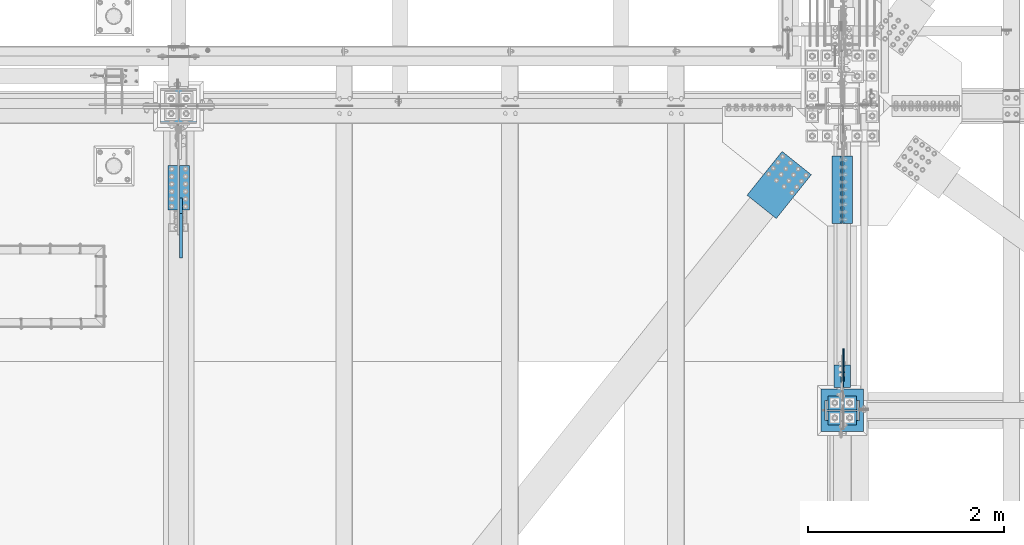
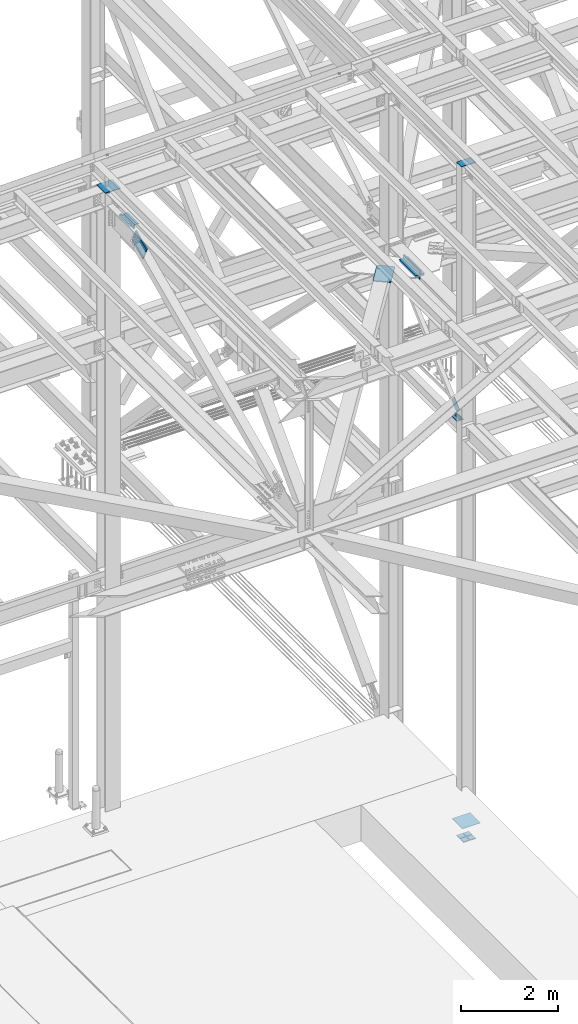
# One storey, part 2543 of 3843: 16 beams, 2 members, 11 elements without a shape of their own.
"""IFC2X3 building model written with IfcOpenShell, lengths in millimetres."""

import ifcopenshell
import ifcopenshell.guid

model = None  # the IFC model being written
_history = None  # IfcOwnerHistory: only IFC2X3 demands one
_inside = {}  # id of a spatial element -> (the spatial element, [elements in it])
_under = {}  # id of a project, library or spatial element -> (it, [spatial elements below it])
_declared = {}  # id of a project -> (the project, [libraries it declares])
_typed = {}  # id of a type object -> (the type object, [elements of that type])
_made_of = {}  # id of a material, layer set ... -> (it, [elements and type objects made of it])


def new_model(schema):
    """Start an empty IFC model of exactly this schema.

    Asked for "IFC4X3", IfcOpenShell would pick the latest addendum, in which some entities
    have other attributes; the version numbers below select the first issue.
    IFC2X3 requires an IfcOwnerHistory on every rooted entity: one is made here for all.
    """
    global model, _history
    if schema == "IFC4X3":
        model = ifcopenshell.file(schema_version=(4, 3, 0, 0))
    else:
        model = ifcopenshell.file(schema=schema)
    _inside.clear()
    _under.clear()
    _declared.clear()
    _typed.clear()
    _made_of.clear()
    _history = None
    if model.schema == "IFC2X3":
        org = make("IfcOrganization", Name="unknown")
        user = make(
            "IfcPersonAndOrganization",
            ThePerson=make("IfcPerson", FamilyName="unknown"),
            TheOrganization=org,
        )
        app = make(
            "IfcApplication",
            ApplicationDeveloper=org,
            Version="unknown",
            ApplicationFullName="unknown",
            ApplicationIdentifier="unknown",
        )
        _history = make(
            "IfcOwnerHistory",
            OwningUser=user,
            OwningApplication=app,
            ChangeAction="ADDED",
            CreationDate=0,
        )
    return model


def make(cls, **values):
    """One entity of the class cls with the attributes given. An attribute that is None is left unset."""
    return model.create_entity(
        cls, **{name: value for name, value in values.items() if value is not None}
    )


def rooted(cls, **values):
    """An entity with a GlobalId (a new one), such as an element, a storey or a relation."""
    return make(cls, GlobalId=ifcopenshell.guid.new(), OwnerHistory=_history, **values)


def si_unit(unit_type, name, prefix=None):
    """IfcSIUnit, for example si_unit("LENGTHUNIT", "METRE", prefix="MILLI")."""
    return make("IfcSIUnit", UnitType=unit_type, Prefix=prefix, Name=name)


def assignment(units):
    """IfcUnitAssignment: the units of a project."""
    return None if units is None else make("IfcUnitAssignment", Units=units)


def point(xyz):
    """IfcCartesianPoint."""
    return None if xyz is None else make("IfcCartesianPoint", Coordinates=xyz)


def direction(xyz):
    """IfcDirection."""
    return None if xyz is None else make("IfcDirection", DirectionRatios=xyz)


def frame(location, z_axis=None, x_axis=None):
    """IfcAxis2Placement3D, a coordinate frame: its origin and axes. An axis left out is left unset."""
    return make(
        "IfcAxis2Placement3D",
        Location=point(location),
        Axis=direction(z_axis),
        RefDirection=direction(x_axis),
    )


def origin_with_axes():
    """The frame at (0, 0, 0) with the z axis (0, 0, 1) and the x axis (1, 0, 0) written out."""
    return frame((0.0, 0.0, 0.0), z_axis=(0.0, 0.0, 1.0), x_axis=(1.0, 0.0, 0.0))


def place(relative_to, where):
    """IfcLocalPlacement: puts the frame where relative to a parent placement (None: the world)."""
    return make(
        "IfcLocalPlacement", PlacementRelTo=relative_to, RelativePlacement=where
    )


def context(
    kind, dimensions, precision=None, world=None, true_north=None, identifier=None
):
    """IfcGeometricRepresentationContext, for example the 3D "Model" context."""
    return make(
        "IfcGeometricRepresentationContext",
        ContextIdentifier=identifier,
        ContextType=kind,
        CoordinateSpaceDimension=dimensions,
        Precision=precision,
        WorldCoordinateSystem=world,
        TrueNorth=true_north,
    )


def subcontext(parent, identifier, kind, view, scale=None):
    """IfcGeometricRepresentationSubContext, for example "Body" below "Model"."""
    return make(
        "IfcGeometricRepresentationSubContext",
        ContextIdentifier=identifier,
        ContextType=kind,
        ParentContext=parent,
        TargetScale=scale,
        TargetView=view,
    )


def project(units=None, contexts=None):
    """IfcProject with its units and contexts."""
    return rooted(
        "IfcProject",
        Name="project",
        RepresentationContexts=contexts,
        UnitsInContext=assignment(units),
    )


def spatial(cls, under=None, at=None, **own):
    """A site, building, storey or space (cls), placed at a placement, below another one or the project."""
    s = rooted(cls, ObjectPlacement=at, **own)
    if under is not None:
        _under.setdefault(under.id(), (under, []))[1].append(s)
    return s


def faces_of(points, faces, orient=None, outer=None):
    """IfcFace entities. A face is a list of loops; a loop is a list of indices into points, from 0.

    orient and outer hold one flag for each loop. By default every Orientation is true, the
    first loop of a face is its IfcFaceOuterBound and the others are IfcFaceBound.
    """
    made = []
    for i, loops in enumerate(faces):
        bounds = []
        for j, loop in enumerate(loops):
            is_outer = j == 0 if outer is None else outer[i][j]
            bounds.append(
                make(
                    "IfcFaceOuterBound" if is_outer else "IfcFaceBound",
                    Bound=make("IfcPolyLoop", Polygon=[points[k] for k in loop]),
                    Orientation=True if orient is None else orient[i][j],
                )
            )
        made.append(make("IfcFace", Bounds=bounds))
    return made


def faceted_brep(points, faces, orient=None, outer=None, voids=None):
    """IfcFacetedBrep: a solid bounded by flat faces; with voids (closed shells), ...WithVoids."""
    shared = [point(p) for p in points]
    hull = make("IfcClosedShell", CfsFaces=faces_of(shared, faces, orient, outer))
    if voids is None:
        return make("IfcFacetedBrep", Outer=hull)
    return make(
        "IfcFacetedBrepWithVoids",
        Outer=hull,
        Voids=[
            make(cls, CfsFaces=faces_of(shared, fs, o, b)) for cls, fs, o, b in voids
        ],
    )


def shape(context_of_items, identifier, shape_type, items):
    """IfcShapeRepresentation: the items that make up one representation, for example the "Body"."""
    return make(
        "IfcShapeRepresentation",
        ContextOfItems=context_of_items,
        RepresentationIdentifier=identifier,
        RepresentationType=shape_type,
        Items=items,
    )


def material(Name=None, Category=None):
    """IfcMaterial."""
    return make("IfcMaterial", Name=Name, Category=Category)


def made_of(thing, what):
    """Note that an element or type object is made of a material, layer set ...; save() writes the relation."""
    if what is not None:
        _made_of.setdefault(what.id(), (what, []))[1].append(thing)
    return thing


def type_object(cls, material=None, **own):
    """A type object (cls), such as IfcWallType, which elements share."""
    return made_of(rooted(cls, **own), material)


def element(
    cls,
    number,
    at=None,
    inside=None,
    cuts=None,
    type_object=None,
    material=None,
    context=None,
    identifier="Body",
    shape_type=None,
    held_by="IfcProductDefinitionShape",
    body=None,
    shapes=None,
    **own,
):
    """One element of the class cls, such as IfcWall. Its Tag is "e" and its number.

    at: its placement. inside: the storey or other place that contains it. cuts: it is an
    opening in that element (IfcRelVoidsElement). A single representation is given by context,
    identifier, shape_type and body (its items); several are given by shapes. held_by: the class
    of the entity that holds the representations. save() writes the other relations.
    """
    e = rooted(cls, Tag="e%d" % number, ObjectPlacement=at, **own)
    if body is not None:
        shapes = [shape(context, identifier, shape_type, body)]
    if shapes is not None:
        e.Representation = make(held_by, Representations=shapes)
    if inside is not None:
        _inside.setdefault(inside.id(), (inside, []))[1].append(e)
    if cuts is not None:
        rooted(
            "IfcRelVoidsElement", RelatingBuildingElement=cuts, RelatedOpeningElement=e
        )
    if type_object is not None:
        _typed.setdefault(type_object.id(), (type_object, []))[1].append(e)
    return made_of(e, material)


def aggregate(whole, parts):
    """IfcRelAggregates: a whole, such as a stair, and the parts it consists of."""
    return rooted("IfcRelAggregates", RelatingObject=whole, RelatedObjects=parts)


def save(model, path):
    """Write the relations noted so far, then the file.

    IfcRelAggregates (storeys below a building ...), IfcRelContainedInSpatialStructure (elements
    in a storey), IfcRelDefinesByType, IfcRelAssociatesMaterial and IfcRelDeclares: one each for
    every whole, place, type object, material and project.
    """
    for whole, parts in _under.values():
        aggregate(whole, parts)
    for where, things in _inside.values():
        rooted(
            "IfcRelContainedInSpatialStructure",
            RelatedElements=things,
            RelatingStructure=where,
        )
    for kind, things in _typed.values():
        rooted("IfcRelDefinesByType", RelatedObjects=things, RelatingType=kind)
    for what, things in _made_of.values():
        rooted("IfcRelAssociatesMaterial", RelatedObjects=things, RelatingMaterial=what)
    for by, libraries in _declared.values():
        rooted("IfcRelDeclares", RelatingContext=by, RelatedDefinitions=libraries)
    model.write(path)


model = new_model("IFC2X3")

# Units and contexts
model_context = context("Model", 3, precision=1e-05, world=origin_with_axes())
body_context = subcontext(model_context, "Body", "Model", "MODEL_VIEW")
ifc_project = project(units=[si_unit("LENGTHUNIT", "METRE", prefix="MILLI"), si_unit("AREAUNIT", "SQUARE_METRE"), si_unit("VOLUMEUNIT", "CUBIC_METRE"), si_unit("MASSUNIT", "GRAM", prefix="KILO"), si_unit("TIMEUNIT", "SECOND"), si_unit("PLANEANGLEUNIT", "RADIAN"), si_unit("SOLIDANGLEUNIT", "STERADIAN"), si_unit("THERMODYNAMICTEMPERATUREUNIT", "DEGREE_CELSIUS"), si_unit("LUMINOUSINTENSITYUNIT", "LUMEN")], contexts=[model_context])

# Site, building, storey
site_placement = place(None, origin_with_axes())
site = spatial("IfcSite", under=ifc_project, at=site_placement, CompositionType="ELEMENT")
building_placement = place(site_placement, origin_with_axes())
building = spatial("IfcBuilding", under=site, at=building_placement, Name="Undefined", CompositionType="ELEMENT")
storey_placement = place(building_placement, origin_with_axes())
storey = spatial("IfcBuildingStorey", under=building, at=storey_placement, Name="Undefined", CompositionType="ELEMENT", Elevation=0.0)

# Assembly, beam
assembly_1_placement = place(storey_placement, origin_with_axes())
assembly_1 = element("IfcElementAssembly", 1, at=assembly_1_placement, inside=storey, Name="ANGLE", AssemblyPlace="NOTDEFINED", PredefinedType="RIGID_FRAME")
ifc_material = material(Name="STEEL/A572-50")
beam_type_1 = type_object("IfcBeamType", Name="L3X3X1/4", PredefinedType="NOTDEFINED")
beam_1_placement = place(assembly_1_placement, frame((77057.2499997492, 89348.4687499993, 39617.6500000003), z_axis=(0.0, 0.0, 1.0), x_axis=(0.0, 1.0, 0.0)))
beam_1 = element("IfcBeam", 2, at=beam_1_placement, type_object=beam_type_1, material=ifc_material, Name="ANGLE", ObjectType="L3X3X1/4", context=body_context, shape_type="Brep", body=[
    faceted_brep([(0.0, 38.0999999999985, -38.0999999999985), (0.0, 38.0999999999985, 38.0999999999985), (228.599999999991, 38.1000000000058, 38.0999999999985), (228.599999999991, 38.1000000000058, -38.0999999999985), (0.0, 31.75, 38.0999999999985), (228.599999999991, 31.75, 38.0999999999985), (0.0, 31.75, -31.75), (228.599999999991, 31.75, -31.75), (0.0, -38.0999999999985, -31.75), (228.599999999991, -38.1000000000058, -31.75), (0.0, -38.0999999999985, -38.0999999999985), (228.599999999991, -38.1000000000058, -38.0999999999985)], [[[0, 1, 2, 3]], [[1, 4, 5, 2]], [[4, 6, 7, 5]], [[6, 8, 9, 7]], [[8, 10, 11, 9]], [[10, 0, 3, 11]], [[5, 7, 9, 11, 3, 2]], [[10, 8, 6, 4, 1, 0]]]),
])
aggregate(assembly_1, [beam_1])

assembly_2_placement = place(storey_placement, origin_with_axes())
assembly_2 = element("IfcElementAssembly", 3, at=assembly_2_placement, inside=storey, Name="ANGLE", AssemblyPlace="NOTDEFINED", PredefinedType="RIGID_FRAME")
beam_2_placement = place(assembly_2_placement, frame((76968.3499997492, 89577.0687499993, 39617.6500000003), z_axis=(0.0, 0.0, 1.0), x_axis=(0.0, -1.0, 0.0)))
beam_2 = element("IfcBeam", 4, at=beam_2_placement, type_object=beam_type_1, material=ifc_material, Name="ANGLE", ObjectType="L3X3X1/4", context=body_context, shape_type="Brep", body=[
    faceted_brep([(0.0, 38.0999999999985, -38.0999999999985), (0.0, 38.0999999999985, 38.0999999999985), (228.599999999991, 38.1000000000058, 38.0999999999985), (228.599999999991, 38.1000000000058, -38.0999999999985), (0.0, 31.75, 38.0999999999985), (228.599999999991, 31.75, 38.0999999999985), (0.0, 31.75, -31.75), (228.599999999991, 31.75, -31.75), (0.0, -38.0999999999985, -31.75), (228.599999999991, -38.1000000000058, -31.75), (0.0, -38.0999999999985, -38.0999999999985), (228.599999999991, -38.1000000000058, -38.0999999999985)], [[[0, 1, 2, 3]], [[1, 4, 5, 2]], [[4, 6, 7, 5]], [[6, 8, 9, 7]], [[8, 10, 11, 9]], [[10, 0, 3, 11]], [[5, 7, 9, 11, 3, 2]], [[10, 8, 6, 4, 1, 0]]]),
])
aggregate(assembly_2, [beam_2])

assembly_3_placement = place(storey_placement, origin_with_axes())
assembly_3 = element("IfcElementAssembly", 5, at=assembly_3_placement, inside=storey, Name="PLATE", AssemblyPlace="NOTDEFINED", PredefinedType="RIGID_FRAME")
beam_type_2 = type_object("IfcBeamType", Name="L4X4X1/2", PredefinedType="NOTDEFINED")
beam_3_placement = place(assembly_3_placement, frame((76957.2375000254, 91020.9, 42297.35), z_axis=(-1.0, 0.0, 0.0), x_axis=(0.0, 1.0, 0.0)))
beam_3 = element("IfcBeam", 6, at=beam_3_placement, type_object=beam_type_2, material=ifc_material, Name="ANGLE", ObjectType="L4X4X1/2", context=body_context, shape_type="Brep", body=[
    faceted_brep([(0.0, 50.8000000000029, -50.8000000000029), (0.0, 50.8000000000029, 50.8000000000029), (685.800000000003, 50.8000000000029, 50.8000000000029), (685.800000000003, 50.8000000000029, -50.8000000000029), (0.0, 38.0999999999985, 50.8000000000029), (685.800000000003, 38.0999999999985, 50.8000000000029), (0.0, 38.0999999999985, -38.0999999999985), (685.800000000003, 38.0999999999985, -38.1000000000058), (0.0, -50.8000000000029, -38.1000000000058), (685.800000000003, -50.8000000000029, -38.1000000000058), (0.0, -50.8000000000029, -50.8000000000029), (685.800000000003, -50.8000000000029, -50.8000000000029)], [[[0, 1, 2, 3]], [[1, 4, 5, 2]], [[4, 6, 7, 5]], [[6, 8, 9, 7]], [[8, 10, 11, 9]], [[10, 0, 3, 11]], [[5, 7, 9, 11, 3, 2]], [[10, 8, 6, 4, 1, 0]]]),
])

assembly_4_placement = place(storey_placement, origin_with_axes())
assembly_4 = element("IfcElementAssembly", 7, at=assembly_4_placement, inside=storey, Name="PLATE", AssemblyPlace="NOTDEFINED", PredefinedType="RIGID_FRAME")
beam_4_placement = place(assembly_4_placement, frame((77068.3624999952, 91706.7, 42297.3500007629), z_axis=(1.0, 0.0, 0.0), x_axis=(0.0, -1.0, 0.0)))
beam_4 = element("IfcBeam", 8, at=beam_4_placement, type_object=beam_type_2, material=ifc_material, Name="ANGLE", ObjectType="L4X4X1/2", context=body_context, shape_type="Brep", body=[
    faceted_brep([(0.0, 50.8000000000029, -50.8000000000029), (0.0, 50.8000000000029, 50.8000000000029), (685.800000000003, 50.8000000000029, 50.8000000000029), (685.800000000003, 50.8000000000029, -50.8000000000029), (0.0, 38.0999999999985, 50.8000000000029), (685.800000000003, 38.0999999999985, 50.8000000000029), (0.0, 38.0999999999985, -38.0999999999985), (685.800000000003, 38.0999999999985, -38.1000000000058), (0.0, -50.8000000000029, -38.1000000000058), (685.800000000003, -50.8000000000029, -38.1000000000058), (0.0, -50.8000000000029, -50.8000000000029), (685.800000000003, -50.8000000000029, -50.8000000000029)], [[[0, 1, 2, 3]], [[1, 4, 5, 2]], [[4, 6, 7, 5]], [[6, 8, 9, 7]], [[8, 10, 11, 9]], [[10, 0, 3, 11]], [[5, 7, 9, 11, 3, 2]], [[10, 8, 6, 4, 1, 0]]]),
])

# Assembly, beams
assembly_5_placement = place(storey_placement, origin_with_axes())
assembly_5 = element("IfcElementAssembly", 9, at=assembly_5_placement, inside=storey, Name="PLATE", AssemblyPlace="NOTDEFINED", PredefinedType="RIGID_FRAME")
beam_5_placement = place(assembly_5_placement, frame((70315.1375000044, 91611.45, 45745.5121203287), z_axis=(0.0, 0.0, -1.0), x_axis=(0.0, -1.0, 0.0)))
beam_5 = element("IfcBeam", 10, at=beam_5_placement, type_object=beam_type_2, material=ifc_material, Name="ANGLE", ObjectType="L4X4X1/2", context=body_context, shape_type="Brep", body=[
    faceted_brep([(0.0, 50.8000000000029, -50.8000000000029), (0.0, 50.8000000000029, 50.8000000000029), (457.199999999997, 50.8000000000029, 50.8000000000029), (457.199999999997, 50.8000000000029, -50.8000000000029), (0.0, 38.0999999999985, 50.8000000000029), (457.199999999997, 38.0999999999985, 50.8000000000029), (0.0, 38.0999999999985, -38.0999999999985), (457.199999999997, 38.0999999999985, -38.0999999999985), (0.0, -50.8000000000029, -38.1000000000058), (457.199999999997, -50.8000000000029, -38.0999999999985), (0.0, -50.8000000000029, -50.8000000000029), (457.199999999997, -50.8000000000029, -50.8000000000029)], [[[0, 1, 2, 3]], [[1, 4, 5, 2]], [[4, 6, 7, 5]], [[6, 8, 9, 7]], [[8, 10, 11, 9]], [[10, 0, 3, 11]], [[5, 7, 9, 11, 3, 2]], [[10, 8, 6, 4, 1, 0]]]),
])
beam_6_placement = place(assembly_5_placement, frame((70197.6625000044, 91154.25, 45745.5121203312), z_axis=(0.0, 0.0, -1.0), x_axis=(0.0, 1.0, 0.0)))
beam_6 = element("IfcBeam", 11, at=beam_6_placement, type_object=beam_type_2, material=ifc_material, Name="ANGLE", ObjectType="L4X4X1/2", context=body_context, shape_type="Brep", body=[
    faceted_brep([(0.0, 50.8000000000029, -50.8000000000029), (0.0, 50.8000000000029, 50.8000000000029), (457.199999999997, 50.8000000000029, 50.8000000000029), (457.199999999997, 50.8000000000029, -50.8000000000029), (0.0, 38.0999999999985, 50.8000000000029), (457.199999999997, 38.0999999999985, 50.8000000000029), (0.0, 38.0999999999985, -38.0999999999985), (457.199999999997, 38.0999999999985, -38.0999999999985), (0.0, -50.8000000000029, -38.1000000000058), (457.199999999997, -50.8000000000029, -38.0999999999985), (0.0, -50.8000000000029, -50.8000000000029), (457.199999999997, -50.8000000000029, -50.8000000000029)], [[[0, 1, 2, 3]], [[1, 4, 5, 2]], [[4, 6, 7, 5]], [[6, 8, 9, 7]], [[8, 10, 11, 9]], [[10, 0, 3, 11]], [[5, 7, 9, 11, 3, 2]], [[10, 8, 6, 4, 1, 0]]]),
])
aggregate(assembly_5, [beam_5, beam_6])

# Beam
beam_type_3 = type_object("IfcBeamType", Name="L4X3-1/2X1/2", PredefinedType="NOTDEFINED")
beam_7_placement = place(assembly_3_placement, frame((76957.2375000048, 91706.7, 42173.525), z_axis=(-1.0, 0.0, 0.0), x_axis=(0.0, -1.0, 0.0)))
beam_7 = element("IfcBeam", 12, at=beam_7_placement, type_object=beam_type_3, material=ifc_material, Name="ANGLE", ObjectType="L4X3-1/2X1/2", context=body_context, shape_type="Brep", body=[
    faceted_brep([(0.0, 44.4499999999971, -50.8000000000029), (0.0, 44.4499999999971, 50.8000000000029), (685.800000000003, 44.4499999999971, 50.8000000000029), (685.800000000003, 44.4499999999971, -50.8000000000029), (0.0, 31.75, 50.8000000000029), (685.800000000003, 31.75, 50.8000000000029), (0.0, 31.7500000838336, -38.0999999999985), (685.800000000003, 31.75, -38.0999999999985), (4.36557456851006e-11, -44.4500000000226, -38.0999999999985), (685.800000000003, -44.4499999999971, -38.0999999999985), (0.0, -44.4499999999971, -50.8000000000029), (685.800000000003, -44.4499999999971, -50.8000000000029)], [[[0, 1, 2, 3]], [[1, 4, 5, 2]], [[4, 6, 7, 5]], [[6, 8, 9, 7]], [[8, 10, 11, 9]], [[10, 0, 3, 11]], [[5, 7, 9, 11, 3, 2]], [[10, 8, 6, 4, 1, 0]]]),
])

aggregate(assembly_3, [beam_7, beam_3])

beam_8_placement = place(assembly_4_placement, frame((77068.3624999952, 91020.9, 42173.525), z_axis=(1.0, 0.0, 0.0), x_axis=(0.0, 1.0, 0.0)))
beam_8 = element("IfcBeam", 13, at=beam_8_placement, type_object=beam_type_3, material=ifc_material, Name="ANGLE", ObjectType="L4X3-1/2X1/2", context=body_context, shape_type="Brep", body=[
    faceted_brep([(0.0, 44.4499999999971, -50.8000000000029), (0.0, 44.4499999999971, 50.8000000000029), (685.800000000003, 44.4499999999971, 50.8000000000029), (685.800000000003, 44.4499999999971, -50.8000000000029), (0.0, 31.75, 50.8000000000029), (685.800000000003, 31.75, 50.8000000000029), (0.0, 31.7500000838336, -38.0999999999985), (685.800000000003, 31.75, -38.0999999999985), (4.36557456851006e-11, -44.4500000000226, -38.0999999999985), (685.800000000003, -44.4499999999971, -38.0999999999985), (0.0, -44.4499999999971, -50.8000000000029), (685.800000000003, -44.4499999999971, -50.8000000000029)], [[[0, 1, 2, 3]], [[1, 4, 5, 2]], [[4, 6, 7, 5]], [[6, 8, 9, 7]], [[8, 10, 11, 9]], [[10, 0, 3, 11]], [[5, 7, 9, 11, 3, 2]], [[10, 8, 6, 4, 1, 0]]]),
])

aggregate(assembly_4, [beam_8, beam_4])

# Assembly, member
assembly_6_placement = place(storey_placement, origin_with_axes())
assembly_6 = element("IfcElementAssembly", 14, at=assembly_6_placement, inside=storey, AssemblyPlace="NOTDEFINED", PredefinedType="RIGID_FRAME")
member_type_1 = type_object("IfcMemberType", PredefinedType="NOTDEFINED")
member_1_placement = place(assembly_6_placement, frame((77025.4999997492, 89470.3974157262, 39746.872748546), z_axis=(0.0, 0.673388817040846, -0.739288510044847), x_axis=(0.0, 0.739288510044838, 0.673388817040857)))
member_1 = element("IfcMember", 15, at=member_1_placement, type_object=member_type_1, material=ifc_material, Name="PLATE", context=body_context, shape_type="Brep", body=[
    faceted_brep([(1.45519152283669e-11, 6.35000000000582, -88.8999999998996), (0.0, 6.34999999999854, 88.9000015258789), (292.099999998526, 6.35000000000582, 88.900000000016), (292.099999999057, 6.35000000000582, -88.8999999997031), (0.0, -6.34999999999854, 88.9000015258789), (292.099999998526, -6.35000000000582, 88.900000000016), (1.45519152283669e-11, -6.35000000000582, -88.8999999998996), (292.099999999057, -6.35000000000582, -88.8999999997031)], [[[0, 1, 2, 3]], [[1, 4, 5, 2]], [[4, 6, 7, 5]], [[6, 0, 3, 7]], [[5, 7, 3, 2]], [[6, 4, 1, 0]]]),
])
aggregate(assembly_6, [member_1])

# Assembly, beam
assembly_7_placement = place(storey_placement, origin_with_axes())
assembly_7 = element("IfcElementAssembly", 16, at=assembly_7_placement, inside=storey, AssemblyPlace="NOTDEFINED", PredefinedType="RIGID_FRAME")
beam_type_4 = type_object("IfcBeamType", PredefinedType="NOTDEFINED")
beam_9_placement = place(assembly_7_placement, frame((76549.0694604425, 91634.5891988166, 42259.25), z_axis=(-0.781103955072164, 0.62440100205767, 0.0), x_axis=(-0.624401003155512, -0.781103954194568, 0.0)))
beam_9 = element("IfcBeam", 17, at=beam_9_placement, type_object=beam_type_4, material=ifc_material, Name="PLATE", context=body_context, shape_type="Brep", body=[
    faceted_brep([(5.85714587941766e-10, 12.6999999999971, -190.500000000349), (-6.14818418398499e-10, 12.6999999999971, 190.500000000364), (571.499999996191, 12.6999999999971, 190.49999999936), (571.499999997392, 12.6999999999971, -190.500000001353), (-6.14818418398499e-10, -12.6999999999971, 190.500000000364), (571.499999996191, -12.6999999999971, 190.49999999936), (5.85714587941766e-10, -12.6999999999971, -190.500000000349), (571.499999997392, -12.6999999999971, -190.500000001353)], [[[0, 1, 2, 3]], [[1, 4, 5, 2]], [[4, 6, 7, 5]], [[6, 0, 3, 7]], [[5, 7, 3, 2]], [[6, 4, 1, 0]]]),
])
aggregate(assembly_7, [beam_9])

assembly_8_placement = place(storey_placement, origin_with_axes())
assembly_8 = element("IfcElementAssembly", 18, at=assembly_8_placement, inside=storey, Name="COLUMN", AssemblyPlace="NOTDEFINED", PredefinedType="RIGID_FRAME")
beam_type_5 = type_object("IfcBeamType", PredefinedType="NOTDEFINED")
beam_10_placement = place(assembly_8_placement, frame((77187.425, 89115.9, 46248.4455507419), z_axis=(0.0, 1.0, 0.0), x_axis=(-1.0, 0.0, 0.0)))
beam_10 = element("IfcBeam", 19, at=beam_10_placement, type_object=beam_type_5, material=ifc_material, Name="PLATE", context=body_context, shape_type="Brep", body=[
    faceted_brep([(1.74622982740402e-10, 6.35000000000582, -101.600000000195), (-1.67347025126219e-10, 6.35000000000582, 101.600000000151), (349.25, 6.34999999999854, 101.600000000006), (349.25, 6.34999999999854, -101.600000000006), (-1.67347025126219e-10, -6.35000000000582, 101.600000000151), (349.25, -6.34999999999854, 101.600000000006), (1.74622982740402e-10, -6.35000000000582, -101.600000000195), (349.25, -6.34999999999854, -101.600000000006)], [[[0, 1, 2, 3]], [[1, 4, 5, 2]], [[4, 6, 7, 5]], [[6, 0, 3, 7]], [[5, 7, 3, 2]], [[6, 4, 1, 0]]]),
])
aggregate(assembly_8, [beam_10])

# Assembly, member
assembly_9_placement = place(storey_placement, origin_with_axes())
assembly_9 = element("IfcElementAssembly", 20, at=assembly_9_placement, inside=storey, AssemblyPlace="NOTDEFINED", PredefinedType="RIGID_FRAME")
member_type_2 = type_object("IfcMemberType", PredefinedType="NOTDEFINED")
member_2_placement = place(assembly_9_placement, frame((70280.2125, 91199.6194438464, 45495.4661426259), z_axis=(0.0, -0.408904208858947, 0.912577310685204), x_axis=(0.0, -0.912577310685201, -0.408904208858954)))
member_2 = element("IfcMember", 21, at=member_2_placement, type_object=member_type_2, material=ifc_material, Name="PLATE", context=body_context, shape_type="Brep", body=[
    faceted_brep([(3.56521923094988e-10, 15.875, -190.500000000146), (-3.61978891305625e-10, 15.875, 190.500000000153), (495.299999995012, 15.875, 190.500000001084), (495.299999995726, 15.875, -190.499999999221), (-3.61978891305625e-10, -15.875, 190.500000000153), (495.299999995012, -15.875, 190.500000001084), (3.56521923094988e-10, -15.875, -190.500000000146), (495.299999995726, -15.875, -190.499999999221)], [[[0, 1, 2, 3]], [[1, 4, 5, 2]], [[4, 6, 7, 5]], [[6, 0, 3, 7]], [[5, 7, 3, 2]], [[6, 4, 1, 0]]]),
])
aggregate(assembly_9, [member_2])

# Assembly, beam
assembly_10_placement = place(storey_placement, origin_with_axes())
assembly_10 = element("IfcElementAssembly", 22, at=assembly_10_placement, inside=storey, Name="COLUMN", AssemblyPlace="NOTDEFINED", PredefinedType="RIGID_FRAME")
beam_type_6 = type_object("IfcBeamType", PredefinedType="NOTDEFINED")
beam_11_placement = place(assembly_10_placement, frame((70256.4, 92036.9, 46119.674442352), z_axis=(1.0, 0.0, 0.0), x_axis=(0.0, 1.0, 0.0)))
beam_11 = element("IfcBeam", 23, at=beam_11_placement, type_object=beam_type_6, material=ifc_material, Name="PLATE", context=body_context, shape_type="Brep", body=[
    faceted_brep([(0.0, 9.52500000000146, -184.150000000001), (0.0, 9.52500000000146, 184.150000000001), (355.600000000006, 9.52500000000146, 184.150000000001), (355.600000000006, 9.52500000000146, -184.150000000001), (0.0, -9.52500000000146, 184.150000000001), (355.600000000006, -9.52500000000146, 184.150000000001), (0.0, -9.52500000000146, -184.150000000001), (355.600000000006, -9.52500000000146, -184.150000000001)], [[[0, 1, 2, 3]], [[1, 4, 5, 2]], [[4, 6, 7, 5]], [[6, 0, 3, 7]], [[5, 7, 3, 2]], [[6, 4, 1, 0]]]),
])
aggregate(assembly_10, [beam_11])

# Assembly, beams
assembly_11_placement = place(storey_placement, origin_with_axes())
assembly_11 = element("IfcElementAssembly", 24, at=assembly_11_placement, inside=storey, Name="TEMPLATE", AssemblyPlace="NOTDEFINED", PredefinedType="RIGID_FRAME")
beam_type_7 = type_object("IfcBeamType", PredefinedType="NOTDEFINED")
beam_12_placement = place(assembly_11_placement, frame((77158.85, 89039.7, 29198.8875), z_axis=(0.0, 1.0, 0.0), x_axis=(-1.0, 0.0, 0.0)))
beam_12 = element("IfcBeam", 25, at=beam_12_placement, type_object=beam_type_7, material=ifc_material, context=body_context, shape_type="Brep", body=[
    faceted_brep([(0.0, 11.1124999999993, -69.8499999999985), (0.0, 11.1124999999993, 69.8499999999985), (139.699999999997, 11.1124999999993, 69.8499999999985), (139.699999999997, 11.1124999999993, -69.8499999999985), (0.0, -11.1124999999993, 69.8499999999985), (139.699999999997, -11.1124999999993, 69.8499999999985), (0.0, -11.1124999999993, -69.8499999999985), (139.699999999997, -11.1124999999993, -69.8499999999985)], [[[0, 1, 2, 3]], [[1, 4, 5, 2]], [[4, 6, 7, 5]], [[6, 0, 3, 7]], [[5, 7, 3, 2]], [[6, 4, 1, 0]]]),
])
beam_13_placement = place(assembly_11_placement, frame((77158.85, 89192.1, 29198.8875), z_axis=(0.0, 1.0, 0.0), x_axis=(-1.0, 0.0, 0.0)))
beam_13 = element("IfcBeam", 26, at=beam_13_placement, type_object=beam_type_7, material=ifc_material, context=body_context, shape_type="Brep", body=[
    faceted_brep([(0.0, 11.1124999999993, -69.8499999999985), (0.0, 11.1124999999993, 69.8499999999985), (139.699999999997, 11.1124999999993, 69.8499999999985), (139.699999999997, 11.1124999999993, -69.8499999999985), (0.0, -11.1124999999993, 69.8499999999985), (139.699999999997, -11.1124999999993, 69.8499999999985), (0.0, -11.1124999999993, -69.8499999999985), (139.699999999997, -11.1124999999993, -69.8499999999985)], [[[0, 1, 2, 3]], [[1, 4, 5, 2]], [[4, 6, 7, 5]], [[6, 0, 3, 7]], [[5, 7, 3, 2]], [[6, 4, 1, 0]]]),
])
beam_14_placement = place(assembly_11_placement, frame((77006.45, 89039.7, 29198.8875), z_axis=(0.0, 1.0, 0.0), x_axis=(-1.0, 0.0, 0.0)))
beam_14 = element("IfcBeam", 27, at=beam_14_placement, type_object=beam_type_7, material=ifc_material, context=body_context, shape_type="Brep", body=[
    faceted_brep([(0.0, 11.1124999999993, -69.8499999999985), (0.0, 11.1124999999993, 69.8499999999985), (139.699999999997, 11.1124999999993, 69.8499999999985), (139.699999999997, 11.1124999999993, -69.8499999999985), (0.0, -11.1124999999993, 69.8499999999985), (139.699999999997, -11.1124999999993, 69.8499999999985), (0.0, -11.1124999999993, -69.8499999999985), (139.699999999997, -11.1124999999993, -69.8499999999985)], [[[0, 1, 2, 3]], [[1, 4, 5, 2]], [[4, 6, 7, 5]], [[6, 0, 3, 7]], [[5, 7, 3, 2]], [[6, 4, 1, 0]]]),
])
beam_15_placement = place(assembly_11_placement, frame((77006.45, 89192.1, 29198.8875), z_axis=(0.0, 1.0, 0.0), x_axis=(-1.0, 0.0, 0.0)))
beam_15 = element("IfcBeam", 28, at=beam_15_placement, type_object=beam_type_7, material=ifc_material, context=body_context, shape_type="Brep", body=[
    faceted_brep([(0.0, 11.1124999999993, -69.8499999999985), (0.0, 11.1124999999993, 69.8499999999985), (139.699999999997, 11.1124999999993, 69.8499999999985), (139.699999999997, 11.1124999999993, -69.8499999999985), (0.0, -11.1124999999993, 69.8499999999985), (139.699999999997, -11.1124999999993, 69.8499999999985), (0.0, -11.1124999999993, -69.8499999999985), (139.699999999997, -11.1124999999993, -69.8499999999985)], [[[0, 1, 2, 3]], [[1, 4, 5, 2]], [[4, 6, 7, 5]], [[6, 0, 3, 7]], [[5, 7, 3, 2]], [[6, 4, 1, 0]]]),
])
beam_type_8 = type_object("IfcBeamType", PredefinedType="NOTDEFINED")
beam_16_placement = place(assembly_11_placement, frame((77228.7, 89115.9, 29606.875), z_axis=(0.0, -1.0, 0.0), x_axis=(-1.0, 0.0, 0.0)))
beam_16 = element("IfcBeam", 29, at=beam_16_placement, type_object=beam_type_8, material=ifc_material, Name="TEMPLATE", context=body_context, shape_type="Brep", body=[
    faceted_brep([(0.0, 3.17499999999927, -215.900000000001), (0.0, 3.17499999999927, 215.900000000001), (431.799999999988, 3.17499999999927, 215.900000000001), (431.799999999988, 3.17499999999927, -215.900000000001), (0.0, -3.17499999999927, 215.900000000001), (431.799999999988, -3.17499999999927, 215.900000000001), (0.0, -3.17499999999927, -215.900000000001), (431.799999999988, -3.17499999999927, -215.900000000001)], [[[0, 1, 2, 3]], [[1, 4, 5, 2]], [[4, 6, 7, 5]], [[6, 0, 3, 7]], [[5, 7, 3, 2]], [[6, 4, 1, 0]]]),
])
aggregate(assembly_11, [beam_12, beam_13, beam_14, beam_15, beam_16])

save(model, "model.ifc")
